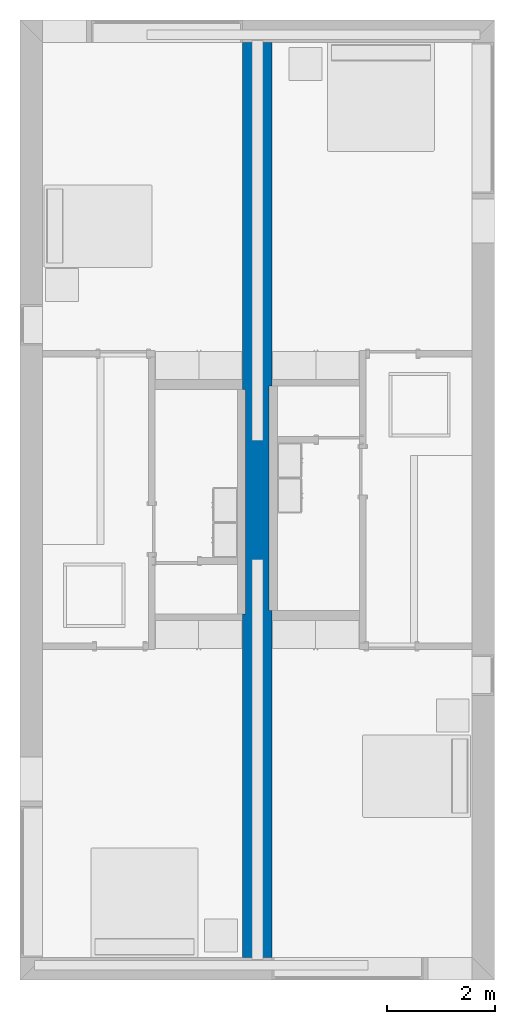
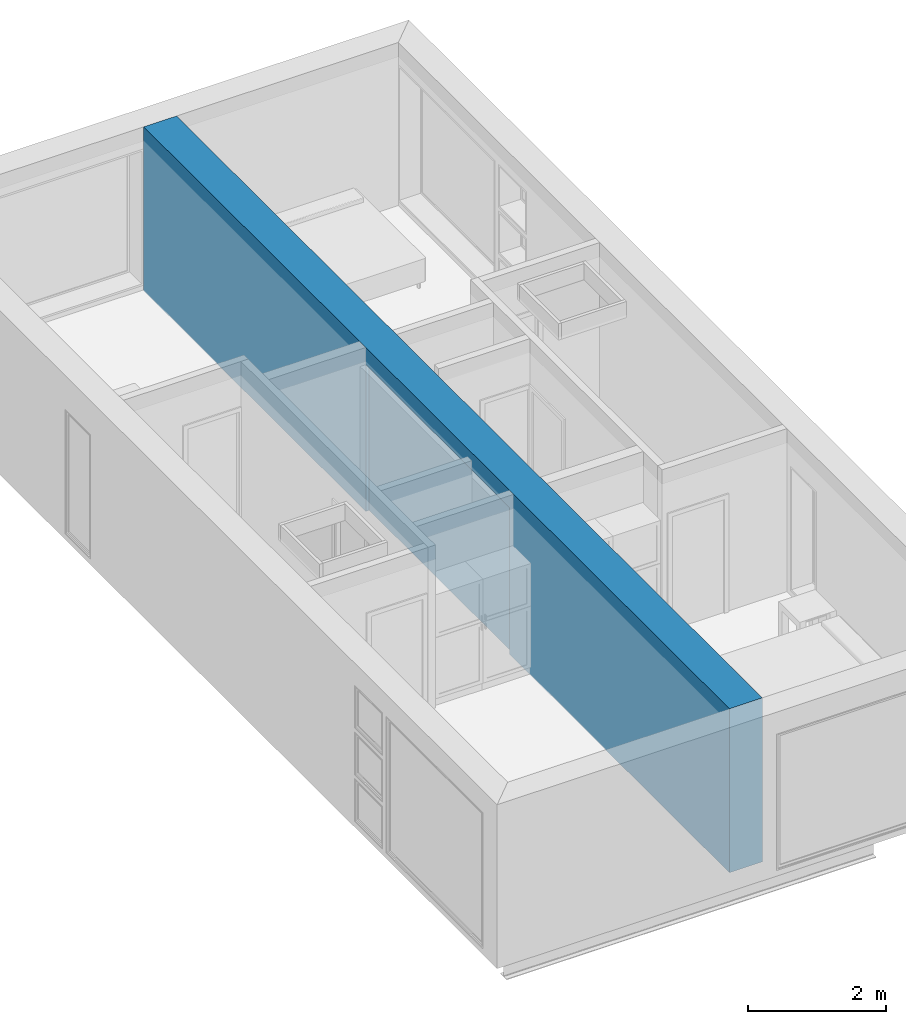
# One storey, part 5 of 10: 1 wall.
"""IFC2X3 building model written with IfcOpenShell, lengths in metres."""

from ifc_helpers import new_model, entity, si_unit, converted_unit, derived_unit, direction, frame, origin, place, context, subcontext, project, spatial, faceted_brep, material, layer, layer_set, type_object, element, save


model = new_model("IFC2X3")

# Units and contexts
model_context = context("Model", 3, precision=1e-05, world=origin(), true_north=direction((6.12303176911189e-17, 1.0)))
body_context = subcontext(model_context, "Body", "Model", "MODEL_VIEW")
ifc_project = project(units=[derived_unit("USERDEFINED", [(si_unit("LENGTHUNIT", "METRE"), -2), (si_unit("TIMEUNIT", "SECOND"), -2), (si_unit("MASSUNIT", "GRAM", prefix="KILO"), 1)]), si_unit("FREQUENCYUNIT", "HERTZ"), si_unit("LENGTHUNIT", "METRE"), si_unit("ILLUMINANCEUNIT", "LUX"), derived_unit("LINEARVELOCITYUNIT", [(si_unit("TIMEUNIT", "SECOND"), -1), (si_unit("LENGTHUNIT", "METRE"), 1)]), si_unit("POWERUNIT", "WATT"), si_unit("LUMINOUSINTENSITYUNIT", "CANDELA"), si_unit("AREAUNIT", "SQUARE_METRE"), si_unit("VOLUMEUNIT", "CUBIC_METRE"), si_unit("ELECTRICVOLTAGEUNIT", "VOLT"), si_unit("PRESSUREUNIT", "PASCAL"), converted_unit("PLANEANGLEUNIT", "DEGREE", entity("IfcRatioMeasure", 0.0174532925199433), si_unit("PLANEANGLEUNIT", "RADIAN"), dimensions=[0, 0, 0, 0, 0, 0, 0]), si_unit("THERMODYNAMICTEMPERATUREUNIT", "DEGREE_CELSIUS"), si_unit("MASSUNIT", "GRAM", prefix="KILO"), derived_unit("VOLUMETRICFLOWRATEUNIT", [(si_unit("LENGTHUNIT", "METRE"), 3), (si_unit("TIMEUNIT", "SECOND"), -1)]), si_unit("TIMEUNIT", "SECOND"), si_unit("LUMINOUSFLUXUNIT", "LUMEN"), derived_unit("USERDEFINED", [(si_unit("LUMINOUSFLUXUNIT", "LUMEN"), 1), (si_unit("TIMEUNIT", "SECOND"), 3), (si_unit("MASSUNIT", "GRAM", prefix="KILO"), -1), (si_unit("LENGTHUNIT", "METRE"), -2)]), si_unit("FORCEUNIT", "NEWTON", prefix="KILO"), si_unit("ELECTRICCURRENTUNIT", "AMPERE"), derived_unit("THERMALTRANSMITTANCEUNIT", [(si_unit("TIMEUNIT", "SECOND"), -3), (si_unit("THERMODYNAMICTEMPERATUREUNIT", "KELVIN"), -1), (si_unit("MASSUNIT", "GRAM", prefix="KILO"), 1)])], contexts=[model_context])

# Site, building, storey
site_placement = place(None, origin())
site = spatial("IfcSite", under=ifc_project, at=site_placement, CompositionType="ELEMENT")
building_placement = place(site_placement, origin())
building = spatial("IfcBuilding", under=site, at=building_placement, CompositionType="ELEMENT")
storey_placement = place(building_placement, frame((0.0, 0.0, 3.10000000000038)))
storey = spatial("IfcBuildingStorey", under=building, at=storey_placement, Name="Level 2", CompositionType="ELEMENT", Elevation=3.10000000000038)

# Wall
ifc_material_1 = material(Name="Plasterboard")
ifc_layer_1 = layer(ifc_material_1, 0.016)
ifc_material_2 = material(Name="Metal - Stud Layer")
ifc_layer_2 = layer(ifc_material_2, 0.041)
ifc_material_3 = material(Name="Masonry - Concrete Block")
ifc_layer_3 = layer(ifc_material_3, 0.193)
ifc_material_4 = material(Name="Misc. Air Layers - Air Space")
ifc_layer_4 = layer(ifc_material_4, 0.05)
ifc_layer_5 = layer(ifc_material_3, 0.193)
ifc_layer_6 = layer(ifc_material_2, 0.041)
ifc_layer_7 = layer(ifc_material_1, 0.016)
ifc_layer_set = layer_set([ifc_layer_1, ifc_layer_2, ifc_layer_3, ifc_layer_4, ifc_layer_5, ifc_layer_6, ifc_layer_7])
wall_type = type_object("IfcWallType", PredefinedType="STANDARD", material=ifc_layer_set)
wall_placement = place(storey_placement, frame((4.4, -0.417000000000014, 0.0), z_axis=(0.0, 0.0, 1.0), x_axis=(0.0, -1.0, 0.0)))
element("IfcWall", 1, at=wall_placement, inside=storey, type_object=wall_type, context=body_context, shape_type="Brep", body=[
    faceted_brep([(0.0, -0.275, 0.0), (0.0, 0.275, 0.0), (6.24899999999999, 0.275000000000001, 0.0), (6.37299999999999, 0.275, 0.0), (6.37299999999999, 0.218, 0.0), (10.533, 0.218000000000001, 0.0), (10.533, 0.275000000000001, 0.0), (10.717, 0.275, 0.0), (16.966, 0.275000000000001, 0.0), (16.966, -0.274999999999999, 0.0), (10.717, -0.275, 0.0), (10.593, -0.274999999999999, 0.0), (10.593, -0.218, 0.0), (6.433, -0.217999999999999, 0.0), (6.433, -0.274999999999999, 0.0), (6.24899999999999, -0.274999999999999, 0.0), (10.533, 0.218000000000001, 2.59500000000001), (6.37299999999999, 0.218, 2.59500000000001), (16.966, -0.274999999999999, 2.90000000000001), (16.966, 0.275000000000001, 0.100000000000004), (16.966, 0.275000000000001, 2.51), (16.966, 0.275000000000001, 2.90000000000001), (0.0, 0.275, 2.90000000000001), (6.24899999999999, 0.275000000000001, 2.90000000000001), (6.37299999999999, 0.275, 2.90000000000001), (10.533, 0.275000000000001, 2.90000000000001), (10.717, 0.275, 2.90000000000001), (10.533, 0.275000000000001, 2.59500000000001), (6.37299999999999, 0.275, 2.59500000000001), (6.43299999999999, -0.217999999999999, 2.59500000000001), (10.593, -0.218, 2.59500000000001), (10.593, -0.274999999999999, 2.59500000000001), (6.433, -0.274999999999999, 2.59500000000001), (0.0, -0.275, 2.90000000000001), (6.249, -0.274999999999999, 2.90000000000001), (6.43299999999999, -0.274999999999999, 2.90000000000001), (10.593, -0.274999999999999, 2.90000000000001), (10.717, -0.275, 2.90000000000001), (0.0, -0.275, 2.51), (0.0, -0.275, 0.100000000000001)], [[[0, 1, 2, 3, 4, 5, 6, 7, 8, 9, 10, 11, 12, 13, 14, 15]], [[16, 5, 4, 17]], [[18, 9, 8, 19, 20, 21]], [[22, 23, 24, 25, 26, 21, 20, 19, 8, 7, 6, 27, 28, 3, 2, 1]], [[29, 30, 31, 32]], [[16, 17, 28, 27]], [[29, 13, 12, 30]], [[13, 29, 32, 14]], [[33, 34, 35, 36, 37, 18, 21, 26, 25, 24, 23, 22]], [[18, 37, 36, 35, 34, 33, 38, 39, 0, 15, 14, 32, 31, 11, 10, 9]], [[30, 12, 11, 31]], [[17, 4, 3, 28]], [[5, 16, 27, 6]], [[0, 39, 38, 33, 22, 1]]]),
])

save(model, "model.ifc")
